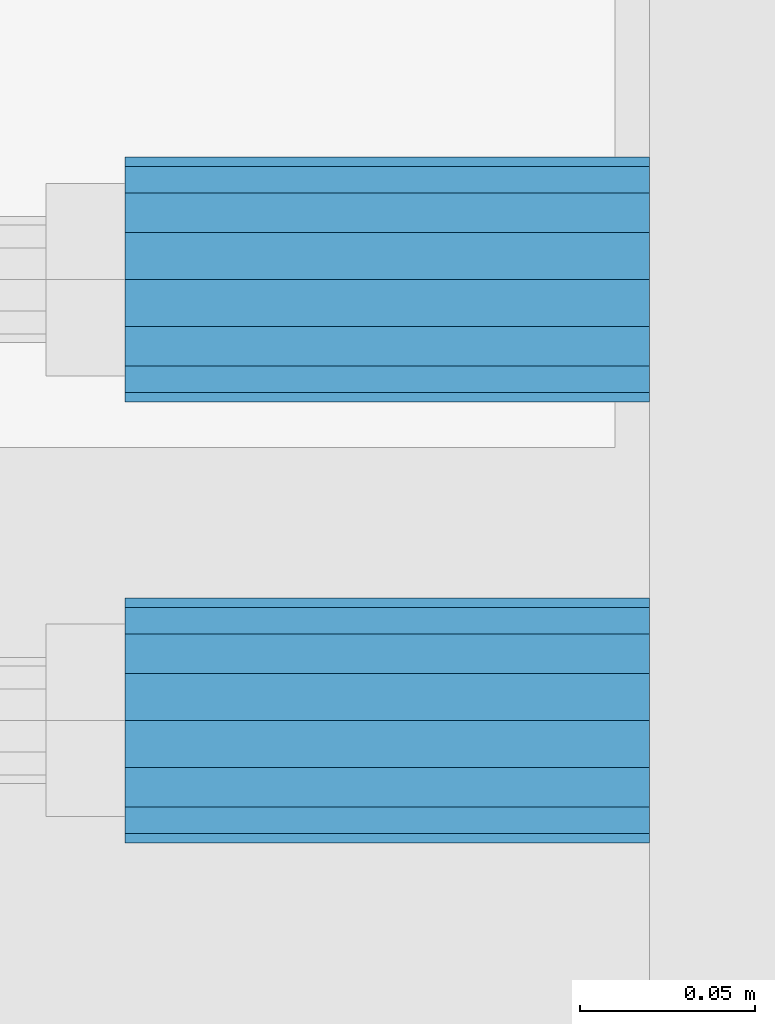
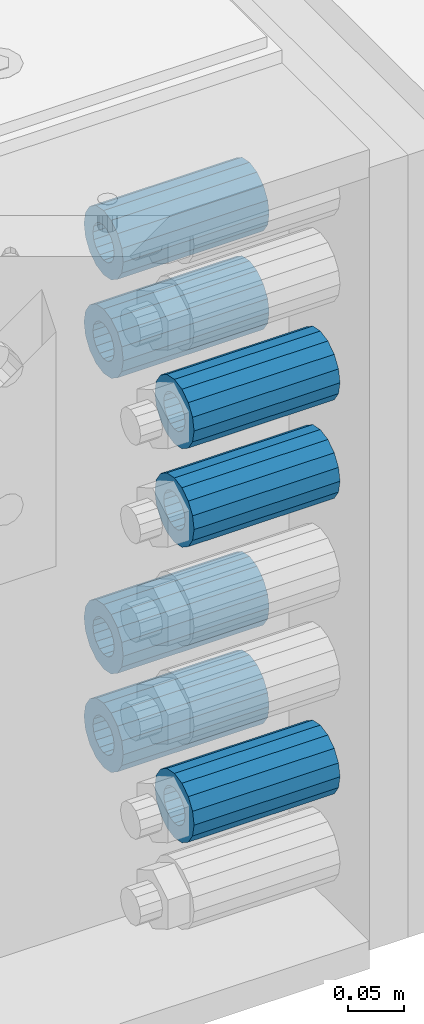
# One storey, part 161 of 257: 7 beams.
"""IFC2X3 building model written with IfcOpenShell, lengths in millimetres."""

from ifc_helpers import new_model, si_unit, frame, origin_with_axes, place, context, subcontext, project, spatial, faceted_brep, material, type_object, element, save


model = new_model("IFC2X3")

# Units and contexts
model_context = context("Model", 3, precision=1e-05, world=origin_with_axes())
body_context = subcontext(model_context, "Body", "Model", "MODEL_VIEW")
ifc_project = project(units=[si_unit("LENGTHUNIT", "METRE", prefix="MILLI"), si_unit("AREAUNIT", "SQUARE_METRE"), si_unit("VOLUMEUNIT", "CUBIC_METRE"), si_unit("MASSUNIT", "GRAM", prefix="KILO"), si_unit("TIMEUNIT", "SECOND"), si_unit("PLANEANGLEUNIT", "RADIAN"), si_unit("SOLIDANGLEUNIT", "STERADIAN"), si_unit("THERMODYNAMICTEMPERATUREUNIT", "DEGREE_CELSIUS"), si_unit("LUMINOUSINTENSITYUNIT", "LUMEN")], contexts=[model_context])

# Site, building, storey
site_placement = place(None, origin_with_axes())
site = spatial("IfcSite", under=ifc_project, at=site_placement, CompositionType="ELEMENT")
building_placement = place(site_placement, origin_with_axes())
building = spatial("IfcBuilding", under=site, at=building_placement, Name="Standard", CompositionType="ELEMENT")
storey_placement = place(building_placement, origin_with_axes())
storey = spatial("IfcBuildingStorey", under=building, at=storey_placement, Name="Undefined", CompositionType="ELEMENT", Elevation=0.0)

# Beams
ifc_material = material()
beam_type = type_object("IfcBeamType", PredefinedType="NOTDEFINED")
beam_1_placement = place(storey_placement, frame((59117.0, -63.0, -392.0), z_axis=(0.0, 0.0, 1.0), x_axis=(1.0, 0.0, 0.0)))
element("IfcBeam", 1, at=beam_1_placement, inside=storey, type_object=beam_type, material=ifc_material, context=body_context, shape_type="Brep", body=[
    faceted_brep([(-1.3120632047503e-07, -18.9999999995493, -6.27187546342611e-09), (0.0, -17.5537111177146, 7.27098521493672), (150.0, -17.5537111177146, 7.27098521493672), (150.0, -19.0, 0.0), (0.0, -13.4350288425449, 13.4350288425444), (150.0, -13.4350288425449, 13.4350288425444), (0.0, -7.27098521493645, 17.5537111177144), (150.0, -7.27098521493645, 17.5537111177144), (-6.33792751614237e-09, 4.50654624728486e-10, 18.9999999937208), (150.0, 0.0, 19.0), (0.0, 7.27098521493645, 17.5537111177144), (150.0, 7.27098521493645, 17.5537111177144), (0.0, 13.4350288425449, 13.4350288425444), (150.0, 13.4350288425449, 13.4350288425444), (0.0, 17.5537111177146, 7.2709852149367), (150.0, 17.5537111177146, 7.2709852149367), (1.33208345687308e-07, 19.0000000004507, -6.27187546342611e-09), (150.0, 19.0, 0.0), (0.0, 17.5537111177146, -7.2709852149367), (150.0, 17.5537111177146, -7.2709852149367), (0.0, 13.4350288425449, -13.4350288425444), (150.0, 13.4350288425449, -13.4350288425444), (0.0, 7.27098521493645, -17.5537111177144), (150.0, 7.27098521493645, -17.5537111177144), (8.33983904158231e-09, 4.50654624728486e-10, -19.0000000062719), (150.0, 0.0, -19.0), (0.0, -7.27098521493645, -17.5537111177144), (150.0, -7.27098521493645, -17.5537111177144), (0.0, -13.4350288425449, -13.4350288425444), (150.0, -13.4350288425449, -13.4350288425444), (0.0, -17.5537111177146, -7.2709852149367), (150.0, -17.5537111177146, -7.2709852149367), (7.27595761418343e-12, -35.0, 0.0), (1.45519152283669e-11, -32.335783637895, -13.3939201327781), (150.0, -32.3357836378955, -13.3939201327782), (150.0, -35.0, 0.0), (7.27595761418343e-12, -24.7487373415292, -24.748737341529), (150.0, -24.7487373415288, -24.7487373415292), (7.27595761418343e-12, -13.3939201327781, -32.335783637895), (150.0, -13.3939201327785, -32.335783637895), (7.27595761418343e-12, 0.0, -35.0), (150.0, 0.0, -35.0), (7.27595761418343e-12, 13.3939201327782, -32.335783637895), (150.0, 13.3939201327785, -32.335783637895), (7.27595761418343e-12, 24.7487373415292, -24.748737341529), (150.0, 24.7487373415288, -24.7487373415292), (1.45519152283669e-11, 32.335783637895, -13.3939201327781), (150.0, 32.3357836378955, -13.3939201327781), (7.27595761418343e-12, 35.0, 0.0), (150.0, 35.0, 0.0), (7.27595761418343e-12, 32.335783637895, 13.3939201327782), (150.0, 32.3357836378955, 13.3939201327781), (7.27595761418343e-12, 24.7487373415292, 24.7487373415291), (150.0, 24.7487373415288, 24.7487373415292), (1.45519152283669e-11, 13.3939201327781, 32.335783637895), (150.0, 13.3939201327785, 32.335783637895), (1.45519152283669e-11, 0.0, 35.0000000000001), (150.0, 0.0, 35.0), (1.45519152283669e-11, -13.3939201327781, 32.335783637895), (150.0, -13.3939201327785, 32.335783637895), (7.27595761418343e-12, -24.7487373415292, 24.7487373415291), (150.0, -24.7487373415288, 24.7487373415292), (7.27595761418343e-12, -32.335783637895, 13.3939201327782), (150.0, -32.3357836378955, 13.3939201327781)], [[[0, 1, 2, 3]], [[1, 4, 5, 2]], [[4, 6, 7, 5]], [[6, 8, 9, 7]], [[8, 10, 11, 9]], [[10, 12, 13, 11]], [[12, 14, 15, 13]], [[14, 16, 17, 15]], [[16, 18, 19, 17]], [[18, 20, 21, 19]], [[20, 22, 23, 21]], [[22, 24, 25, 23]], [[24, 26, 27, 25]], [[26, 28, 29, 27]], [[28, 30, 31, 29]], [[30, 0, 3, 31]], [[32, 33, 34, 35]], [[33, 36, 37, 34]], [[36, 38, 39, 37]], [[38, 40, 41, 39]], [[40, 42, 43, 41]], [[42, 44, 45, 43]], [[44, 46, 47, 45]], [[46, 48, 49, 47]], [[48, 50, 51, 49]], [[50, 52, 53, 51]], [[52, 54, 55, 53]], [[54, 56, 57, 55]], [[56, 58, 59, 57]], [[58, 60, 61, 59]], [[60, 62, 63, 61]], [[62, 32, 35, 63]], [[37, 39, 41, 43, 45, 47, 49, 51, 53, 55, 57, 59, 61, 63, 35, 34], [5, 7, 9, 11, 13, 15, 17, 19, 21, 23, 25, 27, 29, 31, 3, 2]], [[62, 60, 58, 56, 54, 52, 50, 48, 46, 44, 42, 40, 38, 36, 33, 32], [30, 28, 26, 24, 22, 20, 18, 16, 14, 12, 10, 8, 6, 4, 1, 0]]]),
])
beam_2_placement = place(storey_placement, frame((59117.0, 63.0, -713.0), z_axis=(0.0, 0.0, 1.0), x_axis=(1.0, 0.0, 0.0)))
element("IfcBeam", 2, at=beam_2_placement, inside=storey, type_object=beam_type, material=ifc_material, context=body_context, shape_type="Brep", body=[
    faceted_brep([(-1.3120632047503e-07, -18.9999999995493, -6.27187546342611e-09), (0.0, -17.5537111177146, 7.27098521493672), (150.0, -17.5537111177146, 7.27098521493672), (150.0, -19.0, 0.0), (0.0, -13.4350288425449, 13.4350288425444), (150.0, -13.4350288425449, 13.4350288425444), (0.0, -7.27098521493645, 17.5537111177144), (150.0, -7.27098521493645, 17.5537111177144), (-6.33792751614237e-09, 4.50654624728486e-10, 18.9999999937208), (150.0, 0.0, 19.0), (0.0, 7.27098521493645, 17.5537111177144), (150.0, 7.27098521493645, 17.5537111177144), (0.0, 13.4350288425449, 13.4350288425444), (150.0, 13.4350288425449, 13.4350288425444), (0.0, 17.5537111177146, 7.2709852149367), (150.0, 17.5537111177146, 7.2709852149367), (1.33208345687308e-07, 19.0000000004507, -6.27187546342611e-09), (150.0, 19.0, 0.0), (0.0, 17.5537111177146, -7.2709852149367), (150.0, 17.5537111177146, -7.2709852149367), (0.0, 13.4350288425449, -13.4350288425444), (150.0, 13.4350288425449, -13.4350288425444), (0.0, 7.27098521493645, -17.5537111177144), (150.0, 7.27098521493645, -17.5537111177144), (8.33983904158231e-09, 4.50654624728486e-10, -19.0000000062719), (150.0, 0.0, -19.0), (0.0, -7.27098521493645, -17.5537111177144), (150.0, -7.27098521493645, -17.5537111177144), (0.0, -13.4350288425449, -13.4350288425444), (150.0, -13.4350288425449, -13.4350288425444), (0.0, -17.5537111177146, -7.2709852149367), (150.0, -17.5537111177146, -7.2709852149367), (7.27595761418343e-12, -35.0, 0.0), (1.45519152283669e-11, -32.335783637895, -13.3939201327781), (150.0, -32.3357836378955, -13.3939201327782), (150.0, -35.0, 0.0), (7.27595761418343e-12, -24.7487373415292, -24.748737341529), (150.0, -24.7487373415288, -24.7487373415292), (7.27595761418343e-12, -13.3939201327781, -32.335783637895), (150.0, -13.3939201327785, -32.335783637895), (7.27595761418343e-12, 0.0, -35.0), (150.0, 0.0, -35.0), (7.27595761418343e-12, 13.3939201327782, -32.335783637895), (150.0, 13.3939201327785, -32.335783637895), (7.27595761418343e-12, 24.7487373415292, -24.748737341529), (150.0, 24.7487373415288, -24.7487373415292), (1.45519152283669e-11, 32.335783637895, -13.3939201327781), (150.0, 32.3357836378955, -13.3939201327781), (7.27595761418343e-12, 35.0, 0.0), (150.0, 35.0, 0.0), (7.27595761418343e-12, 32.335783637895, 13.3939201327782), (150.0, 32.3357836378955, 13.3939201327781), (7.27595761418343e-12, 24.7487373415292, 24.7487373415291), (150.0, 24.7487373415288, 24.7487373415292), (1.45519152283669e-11, 13.3939201327781, 32.335783637895), (150.0, 13.3939201327785, 32.335783637895), (1.45519152283669e-11, 0.0, 35.0000000000001), (150.0, 0.0, 35.0), (1.45519152283669e-11, -13.3939201327781, 32.335783637895), (150.0, -13.3939201327785, 32.335783637895), (7.27595761418343e-12, -24.7487373415292, 24.7487373415291), (150.0, -24.7487373415288, 24.7487373415292), (7.27595761418343e-12, -32.335783637895, 13.3939201327782), (150.0, -32.3357836378955, 13.3939201327781)], [[[0, 1, 2, 3]], [[1, 4, 5, 2]], [[4, 6, 7, 5]], [[6, 8, 9, 7]], [[8, 10, 11, 9]], [[10, 12, 13, 11]], [[12, 14, 15, 13]], [[14, 16, 17, 15]], [[16, 18, 19, 17]], [[18, 20, 21, 19]], [[20, 22, 23, 21]], [[22, 24, 25, 23]], [[24, 26, 27, 25]], [[26, 28, 29, 27]], [[28, 30, 31, 29]], [[30, 0, 3, 31]], [[32, 33, 34, 35]], [[33, 36, 37, 34]], [[36, 38, 39, 37]], [[38, 40, 41, 39]], [[40, 42, 43, 41]], [[42, 44, 45, 43]], [[44, 46, 47, 45]], [[46, 48, 49, 47]], [[48, 50, 51, 49]], [[50, 52, 53, 51]], [[52, 54, 55, 53]], [[54, 56, 57, 55]], [[56, 58, 59, 57]], [[58, 60, 61, 59]], [[60, 62, 63, 61]], [[62, 32, 35, 63]], [[37, 39, 41, 43, 45, 47, 49, 51, 53, 55, 57, 59, 61, 63, 35, 34], [5, 7, 9, 11, 13, 15, 17, 19, 21, 23, 25, 27, 29, 31, 3, 2]], [[62, 60, 58, 56, 54, 52, 50, 48, 46, 44, 42, 40, 38, 36, 33, 32], [30, 28, 26, 24, 22, 20, 18, 16, 14, 12, 10, 8, 6, 4, 1, 0]]]),
])
beam_3_placement = place(storey_placement, frame((59117.0, 63.0, -178.0), z_axis=(0.0, 0.0, 1.0), x_axis=(1.0, 0.0, 0.0)))
element("IfcBeam", 3, at=beam_3_placement, inside=storey, type_object=beam_type, material=ifc_material, context=body_context, shape_type="Brep", body=[
    faceted_brep([(-1.3120632047503e-07, -18.9999999995493, -6.27187546342611e-09), (0.0, -17.5537111177146, 7.27098521493672), (150.0, -17.5537111177146, 7.27098521493672), (150.0, -19.0, 0.0), (0.0, -13.4350288425449, 13.4350288425444), (150.0, -13.4350288425449, 13.4350288425444), (0.0, -7.27098521493645, 17.5537111177144), (150.0, -7.27098521493645, 17.5537111177144), (-6.33792751614237e-09, 4.50654624728486e-10, 18.9999999937208), (150.0, 0.0, 19.0), (0.0, 7.27098521493645, 17.5537111177144), (150.0, 7.27098521493645, 17.5537111177144), (0.0, 13.4350288425449, 13.4350288425444), (150.0, 13.4350288425449, 13.4350288425444), (0.0, 17.5537111177146, 7.2709852149367), (150.0, 17.5537111177146, 7.2709852149367), (1.33208345687308e-07, 19.0000000004507, -6.27187546342611e-09), (150.0, 19.0, 0.0), (0.0, 17.5537111177146, -7.2709852149367), (150.0, 17.5537111177146, -7.2709852149367), (0.0, 13.4350288425449, -13.4350288425444), (150.0, 13.4350288425449, -13.4350288425444), (0.0, 7.27098521493645, -17.5537111177144), (150.0, 7.27098521493645, -17.5537111177144), (8.33983904158231e-09, 4.50654624728486e-10, -19.0000000062719), (150.0, 0.0, -19.0), (0.0, -7.27098521493645, -17.5537111177144), (150.0, -7.27098521493645, -17.5537111177144), (0.0, -13.4350288425449, -13.4350288425444), (150.0, -13.4350288425449, -13.4350288425444), (0.0, -17.5537111177146, -7.2709852149367), (150.0, -17.5537111177146, -7.2709852149367), (7.27595761418343e-12, -35.0, 0.0), (1.45519152283669e-11, -32.335783637895, -13.3939201327781), (150.0, -32.3357836378955, -13.3939201327782), (150.0, -35.0, 0.0), (7.27595761418343e-12, -24.7487373415292, -24.748737341529), (150.0, -24.7487373415288, -24.7487373415292), (7.27595761418343e-12, -13.3939201327781, -32.335783637895), (150.0, -13.3939201327785, -32.335783637895), (7.27595761418343e-12, 0.0, -35.0), (150.0, 0.0, -35.0), (7.27595761418343e-12, 13.3939201327782, -32.335783637895), (150.0, 13.3939201327785, -32.335783637895), (7.27595761418343e-12, 24.7487373415292, -24.748737341529), (150.0, 24.7487373415288, -24.7487373415292), (1.45519152283669e-11, 32.335783637895, -13.3939201327781), (150.0, 32.3357836378955, -13.3939201327781), (7.27595761418343e-12, 35.0, 0.0), (150.0, 35.0, 0.0), (7.27595761418343e-12, 32.335783637895, 13.3939201327782), (150.0, 32.3357836378955, 13.3939201327781), (7.27595761418343e-12, 24.7487373415292, 24.7487373415291), (150.0, 24.7487373415288, 24.7487373415292), (1.45519152283669e-11, 13.3939201327781, 32.335783637895), (150.0, 13.3939201327785, 32.335783637895), (1.45519152283669e-11, 0.0, 35.0000000000001), (150.0, 0.0, 35.0), (1.45519152283669e-11, -13.3939201327781, 32.335783637895), (150.0, -13.3939201327785, 32.335783637895), (7.27595761418343e-12, -24.7487373415292, 24.7487373415291), (150.0, -24.7487373415288, 24.7487373415292), (7.27595761418343e-12, -32.335783637895, 13.3939201327782), (150.0, -32.3357836378955, 13.3939201327781)], [[[0, 1, 2, 3]], [[1, 4, 5, 2]], [[4, 6, 7, 5]], [[6, 8, 9, 7]], [[8, 10, 11, 9]], [[10, 12, 13, 11]], [[12, 14, 15, 13]], [[14, 16, 17, 15]], [[16, 18, 19, 17]], [[18, 20, 21, 19]], [[20, 22, 23, 21]], [[22, 24, 25, 23]], [[24, 26, 27, 25]], [[26, 28, 29, 27]], [[28, 30, 31, 29]], [[30, 0, 3, 31]], [[32, 33, 34, 35]], [[33, 36, 37, 34]], [[36, 38, 39, 37]], [[38, 40, 41, 39]], [[40, 42, 43, 41]], [[42, 44, 45, 43]], [[44, 46, 47, 45]], [[46, 48, 49, 47]], [[48, 50, 51, 49]], [[50, 52, 53, 51]], [[52, 54, 55, 53]], [[54, 56, 57, 55]], [[56, 58, 59, 57]], [[58, 60, 61, 59]], [[60, 62, 63, 61]], [[62, 32, 35, 63]], [[37, 39, 41, 43, 45, 47, 49, 51, 53, 55, 57, 59, 61, 63, 35, 34], [5, 7, 9, 11, 13, 15, 17, 19, 21, 23, 25, 27, 29, 31, 3, 2]], [[62, 60, 58, 56, 54, 52, 50, 48, 46, 44, 42, 40, 38, 36, 33, 32], [30, 28, 26, 24, 22, 20, 18, 16, 14, 12, 10, 8, 6, 4, 1, 0]]]),
])
beam_4_placement = place(storey_placement, frame((59117.0, 63.0, -606.0), z_axis=(0.0, 0.0, 1.0), x_axis=(1.0, 0.0, 0.0)))
element("IfcBeam", 4, at=beam_4_placement, inside=storey, type_object=beam_type, material=ifc_material, context=body_context, shape_type="Brep", body=[
    faceted_brep([(-1.3120632047503e-07, -18.9999999995493, -6.27187546342611e-09), (0.0, -17.5537111177146, 7.27098521493672), (150.0, -17.5537111177146, 7.27098521493672), (150.0, -19.0, 0.0), (0.0, -13.4350288425449, 13.4350288425444), (150.0, -13.4350288425449, 13.4350288425444), (0.0, -7.27098521493645, 17.5537111177144), (150.0, -7.27098521493645, 17.5537111177144), (-6.33792751614237e-09, 4.50654624728486e-10, 18.9999999937208), (150.0, 0.0, 19.0), (0.0, 7.27098521493645, 17.5537111177144), (150.0, 7.27098521493645, 17.5537111177144), (0.0, 13.4350288425449, 13.4350288425444), (150.0, 13.4350288425449, 13.4350288425444), (0.0, 17.5537111177146, 7.2709852149367), (150.0, 17.5537111177146, 7.2709852149367), (1.33208345687308e-07, 19.0000000004507, -6.27187546342611e-09), (150.0, 19.0, 0.0), (0.0, 17.5537111177146, -7.2709852149367), (150.0, 17.5537111177146, -7.2709852149367), (0.0, 13.4350288425449, -13.4350288425444), (150.0, 13.4350288425449, -13.4350288425444), (0.0, 7.27098521493645, -17.5537111177144), (150.0, 7.27098521493645, -17.5537111177144), (8.33983904158231e-09, 4.50654624728486e-10, -19.0000000062719), (150.0, 0.0, -19.0), (0.0, -7.27098521493645, -17.5537111177144), (150.0, -7.27098521493645, -17.5537111177144), (0.0, -13.4350288425449, -13.4350288425444), (150.0, -13.4350288425449, -13.4350288425444), (0.0, -17.5537111177146, -7.2709852149367), (150.0, -17.5537111177146, -7.2709852149367), (7.27595761418343e-12, -35.0, 0.0), (1.45519152283669e-11, -32.335783637895, -13.3939201327781), (150.0, -32.3357836378955, -13.3939201327782), (150.0, -35.0, 0.0), (7.27595761418343e-12, -24.7487373415292, -24.748737341529), (150.0, -24.7487373415288, -24.7487373415292), (7.27595761418343e-12, -13.3939201327781, -32.335783637895), (150.0, -13.3939201327785, -32.335783637895), (7.27595761418343e-12, 0.0, -35.0), (150.0, 0.0, -35.0), (7.27595761418343e-12, 13.3939201327782, -32.335783637895), (150.0, 13.3939201327785, -32.335783637895), (7.27595761418343e-12, 24.7487373415292, -24.748737341529), (150.0, 24.7487373415288, -24.7487373415292), (1.45519152283669e-11, 32.335783637895, -13.3939201327781), (150.0, 32.3357836378955, -13.3939201327781), (7.27595761418343e-12, 35.0, 0.0), (150.0, 35.0, 0.0), (7.27595761418343e-12, 32.335783637895, 13.3939201327782), (150.0, 32.3357836378955, 13.3939201327781), (7.27595761418343e-12, 24.7487373415292, 24.7487373415291), (150.0, 24.7487373415288, 24.7487373415292), (1.45519152283669e-11, 13.3939201327781, 32.335783637895), (150.0, 13.3939201327785, 32.335783637895), (1.45519152283669e-11, 0.0, 35.0000000000001), (150.0, 0.0, 35.0), (1.45519152283669e-11, -13.3939201327781, 32.335783637895), (150.0, -13.3939201327785, 32.335783637895), (7.27595761418343e-12, -24.7487373415292, 24.7487373415291), (150.0, -24.7487373415288, 24.7487373415292), (7.27595761418343e-12, -32.335783637895, 13.3939201327782), (150.0, -32.3357836378955, 13.3939201327781)], [[[0, 1, 2, 3]], [[1, 4, 5, 2]], [[4, 6, 7, 5]], [[6, 8, 9, 7]], [[8, 10, 11, 9]], [[10, 12, 13, 11]], [[12, 14, 15, 13]], [[14, 16, 17, 15]], [[16, 18, 19, 17]], [[18, 20, 21, 19]], [[20, 22, 23, 21]], [[22, 24, 25, 23]], [[24, 26, 27, 25]], [[26, 28, 29, 27]], [[28, 30, 31, 29]], [[30, 0, 3, 31]], [[32, 33, 34, 35]], [[33, 36, 37, 34]], [[36, 38, 39, 37]], [[38, 40, 41, 39]], [[40, 42, 43, 41]], [[42, 44, 45, 43]], [[44, 46, 47, 45]], [[46, 48, 49, 47]], [[48, 50, 51, 49]], [[50, 52, 53, 51]], [[52, 54, 55, 53]], [[54, 56, 57, 55]], [[56, 58, 59, 57]], [[58, 60, 61, 59]], [[60, 62, 63, 61]], [[62, 32, 35, 63]], [[37, 39, 41, 43, 45, 47, 49, 51, 53, 55, 57, 59, 61, 63, 35, 34], [5, 7, 9, 11, 13, 15, 17, 19, 21, 23, 25, 27, 29, 31, 3, 2]], [[62, 60, 58, 56, 54, 52, 50, 48, 46, 44, 42, 40, 38, 36, 33, 32], [30, 28, 26, 24, 22, 20, 18, 16, 14, 12, 10, 8, 6, 4, 1, 0]]]),
])
beam_5_placement = place(storey_placement, frame((59117.0, 63.0, -285.0), z_axis=(0.0, 0.0, 1.0), x_axis=(1.0, 0.0, 0.0)))
element("IfcBeam", 5, at=beam_5_placement, inside=storey, type_object=beam_type, material=ifc_material, context=body_context, shape_type="Brep", body=[
    faceted_brep([(-1.3120632047503e-07, -18.9999999995493, -6.27187546342611e-09), (0.0, -17.5537111177146, 7.27098521493672), (150.0, -17.5537111177146, 7.27098521493672), (150.0, -19.0, 0.0), (0.0, -13.4350288425449, 13.4350288425444), (150.0, -13.4350288425449, 13.4350288425444), (0.0, -7.27098521493645, 17.5537111177144), (150.0, -7.27098521493645, 17.5537111177144), (-6.33792751614237e-09, 4.50654624728486e-10, 18.9999999937208), (150.0, 0.0, 19.0), (0.0, 7.27098521493645, 17.5537111177144), (150.0, 7.27098521493645, 17.5537111177144), (0.0, 13.4350288425449, 13.4350288425444), (150.0, 13.4350288425449, 13.4350288425444), (0.0, 17.5537111177146, 7.2709852149367), (150.0, 17.5537111177146, 7.2709852149367), (1.33208345687308e-07, 19.0000000004507, -6.27187546342611e-09), (150.0, 19.0, 0.0), (0.0, 17.5537111177146, -7.2709852149367), (150.0, 17.5537111177146, -7.2709852149367), (0.0, 13.4350288425449, -13.4350288425444), (150.0, 13.4350288425449, -13.4350288425444), (0.0, 7.27098521493645, -17.5537111177144), (150.0, 7.27098521493645, -17.5537111177144), (8.33983904158231e-09, 4.50654624728486e-10, -19.0000000062719), (150.0, 0.0, -19.0), (0.0, -7.27098521493645, -17.5537111177144), (150.0, -7.27098521493645, -17.5537111177144), (0.0, -13.4350288425449, -13.4350288425444), (150.0, -13.4350288425449, -13.4350288425444), (0.0, -17.5537111177146, -7.2709852149367), (150.0, -17.5537111177146, -7.2709852149367), (7.27595761418343e-12, -35.0, 0.0), (1.45519152283669e-11, -32.335783637895, -13.3939201327781), (150.0, -32.3357836378955, -13.3939201327782), (150.0, -35.0, 0.0), (7.27595761418343e-12, -24.7487373415292, -24.748737341529), (150.0, -24.7487373415288, -24.7487373415292), (7.27595761418343e-12, -13.3939201327781, -32.335783637895), (150.0, -13.3939201327785, -32.335783637895), (7.27595761418343e-12, 0.0, -35.0), (150.0, 0.0, -35.0), (7.27595761418343e-12, 13.3939201327782, -32.335783637895), (150.0, 13.3939201327785, -32.335783637895), (7.27595761418343e-12, 24.7487373415292, -24.748737341529), (150.0, 24.7487373415288, -24.7487373415292), (1.45519152283669e-11, 32.335783637895, -13.3939201327781), (150.0, 32.3357836378955, -13.3939201327781), (7.27595761418343e-12, 35.0, 0.0), (150.0, 35.0, 0.0), (7.27595761418343e-12, 32.335783637895, 13.3939201327782), (150.0, 32.3357836378955, 13.3939201327781), (7.27595761418343e-12, 24.7487373415292, 24.7487373415291), (150.0, 24.7487373415288, 24.7487373415292), (1.45519152283669e-11, 13.3939201327781, 32.335783637895), (150.0, 13.3939201327785, 32.335783637895), (1.45519152283669e-11, 0.0, 35.0000000000001), (150.0, 0.0, 35.0), (1.45519152283669e-11, -13.3939201327781, 32.335783637895), (150.0, -13.3939201327785, 32.335783637895), (7.27595761418343e-12, -24.7487373415292, 24.7487373415291), (150.0, -24.7487373415288, 24.7487373415292), (7.27595761418343e-12, -32.335783637895, 13.3939201327782), (150.0, -32.3357836378955, 13.3939201327781)], [[[0, 1, 2, 3]], [[1, 4, 5, 2]], [[4, 6, 7, 5]], [[6, 8, 9, 7]], [[8, 10, 11, 9]], [[10, 12, 13, 11]], [[12, 14, 15, 13]], [[14, 16, 17, 15]], [[16, 18, 19, 17]], [[18, 20, 21, 19]], [[20, 22, 23, 21]], [[22, 24, 25, 23]], [[24, 26, 27, 25]], [[26, 28, 29, 27]], [[28, 30, 31, 29]], [[30, 0, 3, 31]], [[32, 33, 34, 35]], [[33, 36, 37, 34]], [[36, 38, 39, 37]], [[38, 40, 41, 39]], [[40, 42, 43, 41]], [[42, 44, 45, 43]], [[44, 46, 47, 45]], [[46, 48, 49, 47]], [[48, 50, 51, 49]], [[50, 52, 53, 51]], [[52, 54, 55, 53]], [[54, 56, 57, 55]], [[56, 58, 59, 57]], [[58, 60, 61, 59]], [[60, 62, 63, 61]], [[62, 32, 35, 63]], [[37, 39, 41, 43, 45, 47, 49, 51, 53, 55, 57, 59, 61, 63, 35, 34], [5, 7, 9, 11, 13, 15, 17, 19, 21, 23, 25, 27, 29, 31, 3, 2]], [[62, 60, 58, 56, 54, 52, 50, 48, 46, 44, 42, 40, 38, 36, 33, 32], [30, 28, 26, 24, 22, 20, 18, 16, 14, 12, 10, 8, 6, 4, 1, 0]]]),
])
beam_6_placement = place(storey_placement, frame((59117.0, -63.0, -285.0), z_axis=(0.0, 0.0, 1.0), x_axis=(1.0, 0.0, 0.0)))
element("IfcBeam", 6, at=beam_6_placement, inside=storey, type_object=beam_type, material=ifc_material, context=body_context, shape_type="Brep", body=[
    faceted_brep([(-1.3120632047503e-07, -18.9999999995493, -6.27187546342611e-09), (0.0, -17.5537111177146, 7.27098521493672), (150.0, -17.5537111177146, 7.27098521493672), (150.0, -19.0, 0.0), (0.0, -13.4350288425449, 13.4350288425444), (150.0, -13.4350288425449, 13.4350288425444), (0.0, -7.27098521493645, 17.5537111177144), (150.0, -7.27098521493645, 17.5537111177144), (-6.33792751614237e-09, 4.50654624728486e-10, 18.9999999937208), (150.0, 0.0, 19.0), (0.0, 7.27098521493645, 17.5537111177144), (150.0, 7.27098521493645, 17.5537111177144), (0.0, 13.4350288425449, 13.4350288425444), (150.0, 13.4350288425449, 13.4350288425444), (0.0, 17.5537111177146, 7.2709852149367), (150.0, 17.5537111177146, 7.2709852149367), (1.33208345687308e-07, 19.0000000004507, -6.27187546342611e-09), (150.0, 19.0, 0.0), (0.0, 17.5537111177146, -7.2709852149367), (150.0, 17.5537111177146, -7.2709852149367), (0.0, 13.4350288425449, -13.4350288425444), (150.0, 13.4350288425449, -13.4350288425444), (0.0, 7.27098521493645, -17.5537111177144), (150.0, 7.27098521493645, -17.5537111177144), (8.33983904158231e-09, 4.50654624728486e-10, -19.0000000062719), (150.0, 0.0, -19.0), (0.0, -7.27098521493645, -17.5537111177144), (150.0, -7.27098521493645, -17.5537111177144), (0.0, -13.4350288425449, -13.4350288425444), (150.0, -13.4350288425449, -13.4350288425444), (0.0, -17.5537111177146, -7.2709852149367), (150.0, -17.5537111177146, -7.2709852149367), (7.27595761418343e-12, -35.0, 0.0), (1.45519152283669e-11, -32.335783637895, -13.3939201327781), (150.0, -32.3357836378955, -13.3939201327782), (150.0, -35.0, 0.0), (7.27595761418343e-12, -24.7487373415292, -24.748737341529), (150.0, -24.7487373415288, -24.7487373415292), (7.27595761418343e-12, -13.3939201327781, -32.335783637895), (150.0, -13.3939201327785, -32.335783637895), (7.27595761418343e-12, 0.0, -35.0), (150.0, 0.0, -35.0), (7.27595761418343e-12, 13.3939201327782, -32.335783637895), (150.0, 13.3939201327785, -32.335783637895), (7.27595761418343e-12, 24.7487373415292, -24.748737341529), (150.0, 24.7487373415288, -24.7487373415292), (1.45519152283669e-11, 32.335783637895, -13.3939201327781), (150.0, 32.3357836378955, -13.3939201327781), (7.27595761418343e-12, 35.0, 0.0), (150.0, 35.0, 0.0), (7.27595761418343e-12, 32.335783637895, 13.3939201327782), (150.0, 32.3357836378955, 13.3939201327781), (7.27595761418343e-12, 24.7487373415292, 24.7487373415291), (150.0, 24.7487373415288, 24.7487373415292), (1.45519152283669e-11, 13.3939201327781, 32.335783637895), (150.0, 13.3939201327785, 32.335783637895), (1.45519152283669e-11, 0.0, 35.0000000000001), (150.0, 0.0, 35.0), (1.45519152283669e-11, -13.3939201327781, 32.335783637895), (150.0, -13.3939201327785, 32.335783637895), (7.27595761418343e-12, -24.7487373415292, 24.7487373415291), (150.0, -24.7487373415288, 24.7487373415292), (7.27595761418343e-12, -32.335783637895, 13.3939201327782), (150.0, -32.3357836378955, 13.3939201327781)], [[[0, 1, 2, 3]], [[1, 4, 5, 2]], [[4, 6, 7, 5]], [[6, 8, 9, 7]], [[8, 10, 11, 9]], [[10, 12, 13, 11]], [[12, 14, 15, 13]], [[14, 16, 17, 15]], [[16, 18, 19, 17]], [[18, 20, 21, 19]], [[20, 22, 23, 21]], [[22, 24, 25, 23]], [[24, 26, 27, 25]], [[26, 28, 29, 27]], [[28, 30, 31, 29]], [[30, 0, 3, 31]], [[32, 33, 34, 35]], [[33, 36, 37, 34]], [[36, 38, 39, 37]], [[38, 40, 41, 39]], [[40, 42, 43, 41]], [[42, 44, 45, 43]], [[44, 46, 47, 45]], [[46, 48, 49, 47]], [[48, 50, 51, 49]], [[50, 52, 53, 51]], [[52, 54, 55, 53]], [[54, 56, 57, 55]], [[56, 58, 59, 57]], [[58, 60, 61, 59]], [[60, 62, 63, 61]], [[62, 32, 35, 63]], [[37, 39, 41, 43, 45, 47, 49, 51, 53, 55, 57, 59, 61, 63, 35, 34], [5, 7, 9, 11, 13, 15, 17, 19, 21, 23, 25, 27, 29, 31, 3, 2]], [[62, 60, 58, 56, 54, 52, 50, 48, 46, 44, 42, 40, 38, 36, 33, 32], [30, 28, 26, 24, 22, 20, 18, 16, 14, 12, 10, 8, 6, 4, 1, 0]]]),
])
beam_7_placement = place(storey_placement, frame((59117.0, -63.0, -713.0), z_axis=(0.0, 0.0, 1.0), x_axis=(1.0, 0.0, 0.0)))
element("IfcBeam", 7, at=beam_7_placement, inside=storey, type_object=beam_type, material=ifc_material, context=body_context, shape_type="Brep", body=[
    faceted_brep([(-1.3120632047503e-07, -18.9999999995493, -6.27187546342611e-09), (0.0, -17.5537111177146, 7.27098521493672), (150.0, -17.5537111177146, 7.27098521493672), (150.0, -19.0, 0.0), (0.0, -13.4350288425449, 13.4350288425444), (150.0, -13.4350288425449, 13.4350288425444), (0.0, -7.27098521493645, 17.5537111177144), (150.0, -7.27098521493645, 17.5537111177144), (-6.33792751614237e-09, 4.50654624728486e-10, 18.9999999937208), (150.0, 0.0, 19.0), (0.0, 7.27098521493645, 17.5537111177144), (150.0, 7.27098521493645, 17.5537111177144), (0.0, 13.4350288425449, 13.4350288425444), (150.0, 13.4350288425449, 13.4350288425444), (0.0, 17.5537111177146, 7.2709852149367), (150.0, 17.5537111177146, 7.2709852149367), (1.33208345687308e-07, 19.0000000004507, -6.27187546342611e-09), (150.0, 19.0, 0.0), (0.0, 17.5537111177146, -7.2709852149367), (150.0, 17.5537111177146, -7.2709852149367), (0.0, 13.4350288425449, -13.4350288425444), (150.0, 13.4350288425449, -13.4350288425444), (0.0, 7.27098521493645, -17.5537111177144), (150.0, 7.27098521493645, -17.5537111177144), (8.33983904158231e-09, 4.50654624728486e-10, -19.0000000062719), (150.0, 0.0, -19.0), (0.0, -7.27098521493645, -17.5537111177144), (150.0, -7.27098521493645, -17.5537111177144), (0.0, -13.4350288425449, -13.4350288425444), (150.0, -13.4350288425449, -13.4350288425444), (0.0, -17.5537111177146, -7.2709852149367), (150.0, -17.5537111177146, -7.2709852149367), (7.27595761418343e-12, -35.0, 0.0), (1.45519152283669e-11, -32.335783637895, -13.3939201327781), (150.0, -32.3357836378955, -13.3939201327782), (150.0, -35.0, 0.0), (7.27595761418343e-12, -24.7487373415292, -24.748737341529), (150.0, -24.7487373415288, -24.7487373415292), (7.27595761418343e-12, -13.3939201327781, -32.335783637895), (150.0, -13.3939201327785, -32.335783637895), (7.27595761418343e-12, 0.0, -35.0), (150.0, 0.0, -35.0), (7.27595761418343e-12, 13.3939201327782, -32.335783637895), (150.0, 13.3939201327785, -32.335783637895), (7.27595761418343e-12, 24.7487373415292, -24.748737341529), (150.0, 24.7487373415288, -24.7487373415292), (1.45519152283669e-11, 32.335783637895, -13.3939201327781), (150.0, 32.3357836378955, -13.3939201327781), (7.27595761418343e-12, 35.0, 0.0), (150.0, 35.0, 0.0), (7.27595761418343e-12, 32.335783637895, 13.3939201327782), (150.0, 32.3357836378955, 13.3939201327781), (7.27595761418343e-12, 24.7487373415292, 24.7487373415291), (150.0, 24.7487373415288, 24.7487373415292), (1.45519152283669e-11, 13.3939201327781, 32.335783637895), (150.0, 13.3939201327785, 32.335783637895), (1.45519152283669e-11, 0.0, 35.0000000000001), (150.0, 0.0, 35.0), (1.45519152283669e-11, -13.3939201327781, 32.335783637895), (150.0, -13.3939201327785, 32.335783637895), (7.27595761418343e-12, -24.7487373415292, 24.7487373415291), (150.0, -24.7487373415288, 24.7487373415292), (7.27595761418343e-12, -32.335783637895, 13.3939201327782), (150.0, -32.3357836378955, 13.3939201327781)], [[[0, 1, 2, 3]], [[1, 4, 5, 2]], [[4, 6, 7, 5]], [[6, 8, 9, 7]], [[8, 10, 11, 9]], [[10, 12, 13, 11]], [[12, 14, 15, 13]], [[14, 16, 17, 15]], [[16, 18, 19, 17]], [[18, 20, 21, 19]], [[20, 22, 23, 21]], [[22, 24, 25, 23]], [[24, 26, 27, 25]], [[26, 28, 29, 27]], [[28, 30, 31, 29]], [[30, 0, 3, 31]], [[32, 33, 34, 35]], [[33, 36, 37, 34]], [[36, 38, 39, 37]], [[38, 40, 41, 39]], [[40, 42, 43, 41]], [[42, 44, 45, 43]], [[44, 46, 47, 45]], [[46, 48, 49, 47]], [[48, 50, 51, 49]], [[50, 52, 53, 51]], [[52, 54, 55, 53]], [[54, 56, 57, 55]], [[56, 58, 59, 57]], [[58, 60, 61, 59]], [[60, 62, 63, 61]], [[62, 32, 35, 63]], [[37, 39, 41, 43, 45, 47, 49, 51, 53, 55, 57, 59, 61, 63, 35, 34], [5, 7, 9, 11, 13, 15, 17, 19, 21, 23, 25, 27, 29, 31, 3, 2]], [[62, 60, 58, 56, 54, 52, 50, 48, 46, 44, 42, 40, 38, 36, 33, 32], [30, 28, 26, 24, 22, 20, 18, 16, 14, 12, 10, 8, 6, 4, 1, 0]]]),
])

save(model, "model.ifc")
